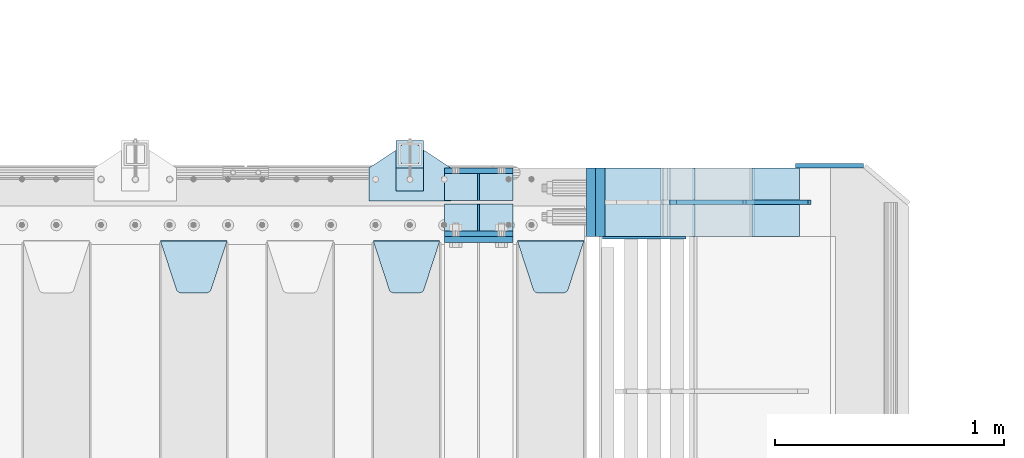
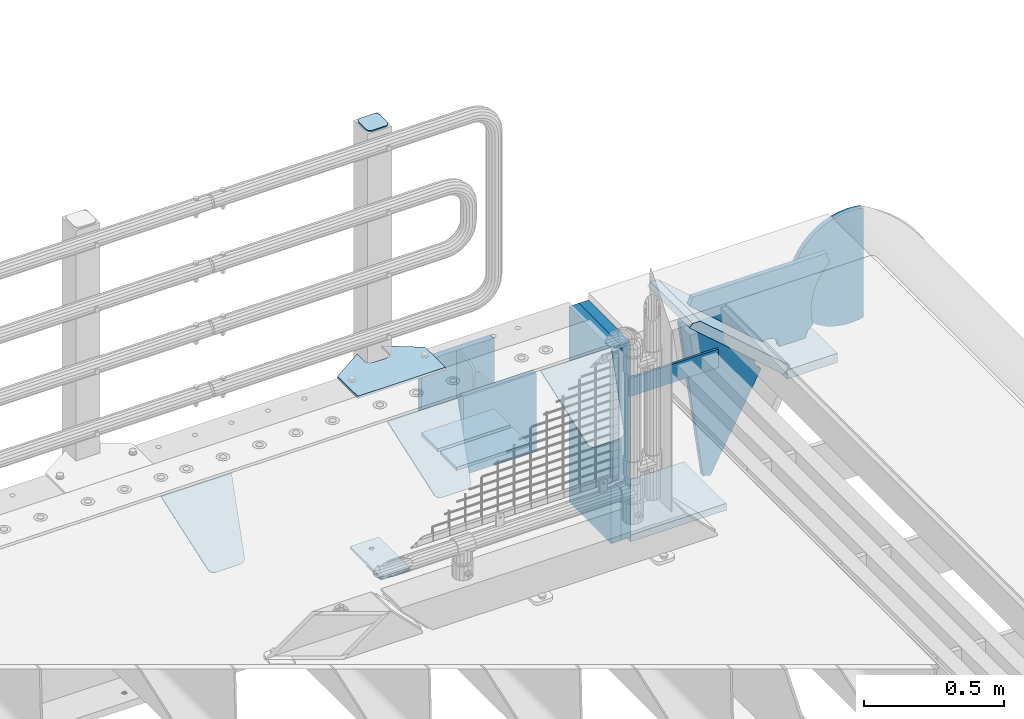
# One storey, part 193 of 208: 23 plates.
"""IFC2X3 building model written with IfcOpenShell, lengths in millimetres."""

from ifc_helpers import new_model, si_unit, frame, origin_with_axes, place, context, subcontext, project, spatial, faceted_brep, material, type_object, element, save


model = new_model("IFC2X3")

# Units and contexts
model_context = context("Model", 3, precision=1e-05, world=origin_with_axes())
body_context = subcontext(model_context, "Body", "Model", "MODEL_VIEW")
ifc_project = project(units=[si_unit("LENGTHUNIT", "METRE", prefix="MILLI"), si_unit("AREAUNIT", "SQUARE_METRE"), si_unit("VOLUMEUNIT", "CUBIC_METRE"), si_unit("MASSUNIT", "GRAM", prefix="KILO"), si_unit("TIMEUNIT", "SECOND"), si_unit("PLANEANGLEUNIT", "RADIAN"), si_unit("SOLIDANGLEUNIT", "STERADIAN"), si_unit("THERMODYNAMICTEMPERATUREUNIT", "DEGREE_CELSIUS"), si_unit("LUMINOUSINTENSITYUNIT", "LUMEN")], contexts=[model_context])

# Site, building, storey
site_placement = place(None, origin_with_axes())
site = spatial("IfcSite", under=ifc_project, at=site_placement, CompositionType="ELEMENT")
building_placement = place(site_placement, origin_with_axes())
building = spatial("IfcBuilding", under=site, at=building_placement, Name="Standard", CompositionType="ELEMENT")
storey_placement = place(building_placement, origin_with_axes())
storey = spatial("IfcBuildingStorey", under=building, at=storey_placement, Name="Undefined", CompositionType="ELEMENT", Elevation=0.0)

# Plates
ifc_material_1 = material(Name="STEEL/S355N")
plate_type_1 = type_object("IfcPlateType", PredefinedType="NOTDEFINED")
for number, where, z_axis, x_axis in (
    (1, (-26255.0, 6137.49999999999, -339.999999999993), (0.0, 0.0, 1.0), (1.0, 0.0, 0.0)),
    (2, (-26255.0, 5862.49999999999, -339.999999999993), (0.0, 0.0, 1.0), (1.0, 0.0, 0.0)),
):
    element("IfcPlate", number, at=place(storey_placement, frame(where, z_axis=z_axis, x_axis=x_axis)), inside=storey, type_object=plate_type_1, material=ifc_material_1, context=body_context, shape_type="Brep", body=[
        faceted_brep([(0.0, -12.5, 0.0), (0.0, -12.5, 310.0), (0.0, 12.5, 310.0), (0.0, 12.5, 0.0), (300.0, -12.5, 310.0), (300.0, 12.5, 310.0), (300.0, -12.5, 0.0), (300.0, 12.5, 0.0)], [[[0, 1, 2, 3]], [[1, 4, 5, 2]], [[4, 6, 7, 5]], [[6, 0, 3, 7]], [[5, 7, 3, 2]], [[6, 4, 1, 0]]]),
    ])
plate_1_placement = place(storey_placement, frame((-26255.0, 5837.5, -340.000000000044), z_axis=(0.0, 0.0, 1.0), x_axis=(1.0, 0.0, 0.0)))
element("IfcPlate", 3, at=plate_1_placement, inside=storey, type_object=plate_type_1, material=ifc_material_1, context=body_context, shape_type="Brep", body=[
    faceted_brep([(0.0, -12.5, 0.0), (0.0, -12.5, 340.0), (0.0, 12.5, 340.0), (0.0, 12.5, 0.0), (300.0, -12.5, 340.0), (300.0, 12.5, 340.0), (300.0, -12.5, 0.0), (300.0, 12.5, 0.0)], [[[0, 1, 2, 3]], [[1, 4, 5, 2]], [[4, 6, 7, 5]], [[6, 0, 3, 7]], [[5, 7, 3, 2]], [[6, 4, 1, 0]]]),
])
plate_type_2 = type_object("IfcPlateType", PredefinedType="NOTDEFINED")
for number, where, z_axis, x_axis in (
    (4, (-26255.0, 5991.99999999999, -342.999999999993), (0.0, -1.0, 0.0), (1.0, 0.0, 0.0)),
    (5, (-26255.0, 6007.99999999999, -342.999999999993), (0.0, 1.0, 0.0), (1.0, 0.0, 0.0)),
):
    element("IfcPlate", number, at=place(storey_placement, frame(where, z_axis=z_axis, x_axis=x_axis)), inside=storey, type_object=plate_type_2, material=ifc_material_1, context=body_context, shape_type="Brep", body=[
        faceted_brep([(0.0, -7.0, 0.0), (0.0, -7.0, 117.0), (0.0, 7.0, 117.0), (0.0, 7.0, 0.0), (300.0, -7.0, 117.0), (300.0, 7.0, 117.0), (300.0, -7.0, 0.0), (300.0, 7.0, 0.0)], [[[0, 1, 2, 3]], [[1, 4, 5, 2]], [[4, 6, 7, 5]], [[6, 0, 3, 7]], [[5, 7, 3, 2]], [[6, 4, 1, 0]]]),
    ])
plate_type_3 = type_object("IfcPlateType", PredefinedType="NOTDEFINED")
for number, where, z_axis, x_axis in (
    (6, (-26105.0, 6007.99999999999, -29.999999999993), (0.0, 0.0, -1.0), (0.0, 1.0, 0.0)),
    (7, (-26105.0, 5991.99999999999, -29.999999999993), (0.0, 0.0, -1.0), (0.0, -1.0, 0.0)),
):
    element("IfcPlate", number, at=place(storey_placement, frame(where, z_axis=z_axis, x_axis=x_axis)), inside=storey, type_object=plate_type_3, material=ifc_material_1, context=body_context, shape_type="Brep", body=[
        faceted_brep([(0.0, -5.0, 30.0), (0.0, -5.0, 306.0), (0.0, 5.0, 306.0), (0.0, 5.0, 30.0), (117.0, -5.0, 306.0), (117.0, 5.0, 306.0), (117.0, -5.0, 0.0), (117.0, 5.0, 0.0), (30.0, -5.0, 0.0), (30.0, 5.0, 0.0), (24.7905546699922, -5.0, 0.455767409633758), (24.7905546699922, 5.0, 0.455767409633758), (19.7393957002296, -5.0, 1.80922137642275), (19.7393957002296, 5.0, 1.80922137642275), (15.0, -5.0, 4.01923788646684), (15.0, 5.0, 4.01923788646684), (10.7163717094036, -5.0, 7.01866670643066), (10.7163717094036, 5.0, 7.01866670643066), (7.01866670643085, -5.0, 10.7163717094038), (7.01866670643085, 5.0, 10.7163717094038), (4.01923788646673, -5.0, 15.0), (4.01923788646673, 5.0, 15.0), (1.80922137642301, -5.0, 19.7393957002299), (1.80922137642301, 5.0, 19.7393957002299), (0.455767409634063, -5.0, 24.7905546699921), (0.455767409634063, 5.0, 24.7905546699921)], [[[0, 1, 2, 3]], [[1, 4, 5, 2]], [[4, 6, 7, 5]], [[6, 8, 9, 7]], [[8, 10, 11, 9]], [[10, 12, 13, 11]], [[12, 14, 15, 13]], [[14, 16, 17, 15]], [[16, 18, 19, 17]], [[18, 20, 21, 19]], [[20, 22, 23, 21]], [[22, 24, 25, 23]], [[24, 0, 3, 25]], [[5, 7, 9, 11, 13, 15, 17, 19, 21, 23, 25, 3, 2]], [[24, 22, 20, 18, 16, 14, 12, 10, 8, 6, 4, 1, 0]]]),
    ])
plate_type_4 = type_object("IfcPlateType", PredefinedType="NOTDEFINED")
plate_2_placement = place(storey_placement, frame((-25935.0, 5831.76776695596, -1.76776695296758), z_axis=(0.0, -0.707106781186548, -0.707106781186547), x_axis=(1.0, 0.0, 0.0)))
element("IfcPlate", 8, at=plate_2_placement, inside=storey, type_object=plate_type_4, material=ifc_material_1, context=body_context, shape_type="Brep", body=[
    faceted_brep([(0.0, -2.5, 0.0), (69.345504679477, -2.5, 300.17173142483), (69.345504679477, 2.5, 300.17173142483), (0.0, 2.5, 0.0), (70.9274061199576, -2.5, 304.897442415399), (70.9274061199576, 2.5, 304.8974424154), (73.3818627772307, -2.5, 309.234538108527), (73.3818627772307, 2.5, 309.234538108527), (76.6187032999551, -2.5, 313.023683126103), (76.6187032999551, 2.5, 313.023683126103), (80.5190132704993, -2.5, 316.125672595371), (80.5190132704993, 2.5, 316.125672595371), (84.9395038596849, -2.5, 318.426546230476), (84.9395038596849, 2.50000000000091, 318.426546230476), (89.7177759439219, -2.5, 319.841774983275), (89.7177759439219, 2.50000000000091, 319.841774983275), (94.678286292652, -2.49999999999909, 320.319366455078), (94.678286292652, 2.5, 320.319366455078), (195.321713707348, -2.49999999999909, 320.319366455078), (195.321713707348, 2.5, 320.319366455078), (200.282224056078, -2.5, 319.841774983275), (200.282224056078, 2.5, 319.841774983274), (205.060496140315, -2.5, 318.426546230475), (205.060496140315, 2.5, 318.426546230475), (209.480986729501, -2.5, 316.125672595371), (209.480986729501, 2.50000000000091, 316.125672595371), (213.381296700045, -2.5, 313.023683126102), (213.381296700045, 2.5, 313.023683126102), (216.618137222769, -2.5, 309.234538108526), (216.618137222769, 2.5, 309.234538108527), (219.072593880042, -2.5, 304.897442415399), (219.072593880042, 2.5, 304.897442415399), (220.654495320523, -2.5, 300.17173142483), (220.654495320523, 2.5, 300.17173142483), (290.0, -2.5, 0.0), (290.0, 2.5, 0.0)], [[[0, 1, 2, 3]], [[1, 4, 5, 2]], [[4, 6, 7, 5]], [[6, 8, 9, 7]], [[8, 10, 11, 9]], [[10, 12, 13, 11]], [[12, 14, 15, 13]], [[14, 16, 17, 15]], [[16, 18, 19, 17]], [[18, 20, 21, 19]], [[20, 22, 23, 21]], [[22, 24, 25, 23]], [[24, 26, 27, 25]], [[26, 28, 29, 27]], [[28, 30, 31, 29]], [[30, 32, 33, 31]], [[32, 34, 35, 33]], [[34, 0, 3, 35]], [[5, 7, 9, 11, 13, 15, 17, 19, 21, 23, 25, 27, 29, 31, 33, 35, 3, 2]], [[34, 32, 30, 28, 26, 24, 22, 20, 18, 16, 14, 12, 10, 8, 6, 4, 1, 0]]]),
])
plate_3_placement = place(storey_placement, frame((-26565.0, 5831.76776695596, -1.76776695296758), z_axis=(0.0, -0.707106781186548, -0.707106781186547), x_axis=(1.0, 0.0, 0.0)))
element("IfcPlate", 9, at=plate_3_placement, inside=storey, type_object=plate_type_4, material=ifc_material_1, context=body_context, shape_type="Brep", body=[
    faceted_brep([(0.0, -2.5, 0.0), (69.345504679477, -2.5, 300.17173142483), (69.345504679477, 2.5, 300.17173142483), (0.0, 2.5, 0.0), (70.9274061199576, -2.5, 304.897442415399), (70.9274061199576, 2.5, 304.8974424154), (73.3818627772307, -2.5, 309.234538108527), (73.3818627772307, 2.5, 309.234538108527), (76.6187032999551, -2.5, 313.023683126103), (76.6187032999551, 2.5, 313.023683126103), (80.5190132704993, -2.5, 316.125672595371), (80.5190132704993, 2.5, 316.125672595371), (84.9395038596849, -2.5, 318.426546230476), (84.9395038596849, 2.50000000000091, 318.426546230476), (89.7177759439219, -2.5, 319.841774983275), (89.7177759439219, 2.50000000000091, 319.841774983275), (94.678286292652, -2.49999999999909, 320.319366455078), (94.678286292652, 2.5, 320.319366455078), (195.321713707348, -2.49999999999909, 320.319366455078), (195.321713707348, 2.5, 320.319366455078), (200.282224056078, -2.5, 319.841774983275), (200.282224056078, 2.5, 319.841774983274), (205.060496140315, -2.5, 318.426546230475), (205.060496140315, 2.5, 318.426546230475), (209.480986729501, -2.5, 316.125672595371), (209.480986729501, 2.50000000000091, 316.125672595371), (213.381296700045, -2.5, 313.023683126102), (213.381296700045, 2.5, 313.023683126102), (216.618137222769, -2.5, 309.234538108526), (216.618137222769, 2.5, 309.234538108527), (219.072593880042, -2.5, 304.897442415399), (219.072593880042, 2.5, 304.897442415399), (220.654495320523, -2.5, 300.17173142483), (220.654495320523, 2.5, 300.17173142483), (290.0, -2.5, 0.0), (290.0, 2.5, 0.0)], [[[0, 1, 2, 3]], [[1, 4, 5, 2]], [[4, 6, 7, 5]], [[6, 8, 9, 7]], [[8, 10, 11, 9]], [[10, 12, 13, 11]], [[12, 14, 15, 13]], [[14, 16, 17, 15]], [[16, 18, 19, 17]], [[18, 20, 21, 19]], [[20, 22, 23, 21]], [[22, 24, 25, 23]], [[24, 26, 27, 25]], [[26, 28, 29, 27]], [[28, 30, 31, 29]], [[30, 32, 33, 31]], [[32, 34, 35, 33]], [[34, 0, 3, 35]], [[5, 7, 9, 11, 13, 15, 17, 19, 21, 23, 25, 27, 29, 31, 33, 35, 3, 2]], [[34, 32, 30, 28, 26, 24, 22, 20, 18, 16, 14, 12, 10, 8, 6, 4, 1, 0]]]),
])
plate_4_placement = place(storey_placement, frame((-27495.0, 5831.76776695596, -1.76776695296758), z_axis=(0.0, -0.707106781186548, -0.707106781186547), x_axis=(1.0, 0.0, 0.0)))
element("IfcPlate", 10, at=plate_4_placement, inside=storey, type_object=plate_type_4, material=ifc_material_1, context=body_context, shape_type="Brep", body=[
    faceted_brep([(0.0, -2.5, 0.0), (69.345504679477, -2.5, 300.17173142483), (69.345504679477, 2.5, 300.17173142483), (0.0, 2.5, 0.0), (70.9274061199576, -2.5, 304.897442415399), (70.9274061199576, 2.5, 304.8974424154), (73.3818627772307, -2.5, 309.234538108527), (73.3818627772307, 2.5, 309.234538108527), (76.6187032999551, -2.5, 313.023683126103), (76.6187032999551, 2.5, 313.023683126103), (80.5190132704993, -2.5, 316.125672595371), (80.5190132704993, 2.5, 316.125672595371), (84.9395038596849, -2.5, 318.426546230476), (84.9395038596849, 2.50000000000091, 318.426546230476), (89.7177759439219, -2.5, 319.841774983275), (89.7177759439219, 2.50000000000091, 319.841774983275), (94.678286292652, -2.49999999999909, 320.319366455078), (94.678286292652, 2.5, 320.319366455078), (195.321713707348, -2.49999999999909, 320.319366455078), (195.321713707348, 2.5, 320.319366455078), (200.282224056078, -2.5, 319.841774983275), (200.282224056078, 2.5, 319.841774983274), (205.060496140315, -2.5, 318.426546230475), (205.060496140315, 2.5, 318.426546230475), (209.480986729501, -2.5, 316.125672595371), (209.480986729501, 2.50000000000091, 316.125672595371), (213.381296700045, -2.5, 313.023683126102), (213.381296700045, 2.5, 313.023683126102), (216.618137222769, -2.5, 309.234538108526), (216.618137222769, 2.5, 309.234538108527), (219.072593880042, -2.5, 304.897442415399), (219.072593880042, 2.5, 304.897442415399), (220.654495320523, -2.5, 300.17173142483), (220.654495320523, 2.5, 300.17173142483), (290.0, -2.5, 0.0), (290.0, 2.5, 0.0)], [[[0, 1, 2, 3]], [[1, 4, 5, 2]], [[4, 6, 7, 5]], [[6, 8, 9, 7]], [[8, 10, 11, 9]], [[10, 12, 13, 11]], [[12, 14, 15, 13]], [[14, 16, 17, 15]], [[16, 18, 19, 17]], [[18, 20, 21, 19]], [[20, 22, 23, 21]], [[22, 24, 25, 23]], [[24, 26, 27, 25]], [[26, 28, 29, 27]], [[28, 30, 31, 29]], [[30, 32, 33, 31]], [[32, 34, 35, 33]], [[34, 0, 3, 35]], [[5, 7, 9, 11, 13, 15, 17, 19, 21, 23, 25, 27, 29, 31, 33, 35, 3, 2]], [[34, 32, 30, 28, 26, 24, 22, 20, 18, 16, 14, 12, 10, 8, 6, 4, 1, 0]]]),
])
ifc_material_2 = material(Name="STEEL/S355J2")
plate_type_5 = type_object("IfcPlateType", PredefinedType="NOTDEFINED")
plate_5_placement = place(storey_placement, frame((-26585.0, 6005.0, 5.00000000004911), z_axis=(0.0, 1.0, 0.0), x_axis=(1.0, 0.0, 0.0)))
element("IfcPlate", 11, at=plate_5_placement, inside=storey, type_object=plate_type_5, material=ifc_material_2, context=body_context, shape_type="Brep", body=[
    faceted_brep([(0.0, -5.0, 0.0), (2.31396552408114e-06, -5.0, 145.0), (2.31396552408114e-06, 5.0, 145.0), (0.0, 5.0, 0.0), (130.0, -5.0, 230.0), (130.0, 5.0, 230.0), (130.0, -5.0, 180.0), (130.0, 5.0, 180.0), (130.48036798992, -5.0, 175.122741949597), (130.48036798992, 5.0, 175.122741949597), (131.903011687216, -5.0, 170.432914190873), (131.903011687216, 5.0, 170.432914190873), (134.213259692435, -5.0, 166.11074417451), (134.213259692435, 5.0, 166.11074417451), (137.322330470335, -5.0, 162.322330470336), (137.322330470335, 5.0, 162.322330470336), (141.110744174512, -5.0, 159.213259692437), (141.110744174512, 5.0, 159.213259692437), (145.432914190871, -5.0, 156.903011687218), (145.432914190871, 5.0, 156.903011687218), (150.122741949595, -5.0, 155.48036798992), (150.122741949595, 5.0, 155.48036798992), (155.0, -5.0, 155.0), (155.0, 5.0, 155.0), (205.0, -5.0, 155.0), (205.0, 5.0, 155.0), (209.877258050405, -5.0, 155.48036798992), (209.877258050405, 5.0, 155.48036798992), (214.567085809129, -5.0, 156.903011687218), (214.567085809129, 5.0, 156.903011687218), (218.889255825488, -5.0, 159.213259692437), (218.889255825488, 5.0, 159.213259692437), (222.677669529665, -5.0, 162.322330470336), (222.677669529665, 5.0, 162.322330470336), (225.786740307565, -5.0, 166.11074417451), (225.786740307565, 5.0, 166.11074417451), (228.096988312784, -5.0, 170.432914190873), (228.096988312784, 5.0, 170.432914190873), (229.51963201008, -5.0, 175.122741949597), (229.51963201008, 5.0, 175.122741949597), (230.0, -5.0, 180.0), (230.0, 5.0, 180.0), (230.0, -5.0, 230.0), (230.0, 5.0, 230.0), (360.0, -5.0, 145.0), (360.0, 5.0, 145.0), (360.0, -5.0, -7.27595761418343e-12), (360.0, 5.0, -7.27595761418343e-12)], [[[0, 1, 2, 3]], [[1, 4, 5, 2]], [[4, 6, 7, 5]], [[6, 8, 9, 7]], [[8, 10, 11, 9]], [[10, 12, 13, 11]], [[12, 14, 15, 13]], [[14, 16, 17, 15]], [[16, 18, 19, 17]], [[18, 20, 21, 19]], [[20, 22, 23, 21]], [[22, 24, 25, 23]], [[24, 26, 27, 25]], [[26, 28, 29, 27]], [[28, 30, 31, 29]], [[30, 32, 33, 31]], [[32, 34, 35, 33]], [[34, 36, 37, 35]], [[36, 38, 39, 37]], [[38, 40, 41, 39]], [[40, 42, 43, 41]], [[42, 44, 45, 43]], [[44, 46, 47, 45]], [[46, 0, 3, 47]], [[5, 7, 9, 11, 13, 15, 17, 19, 21, 23, 25, 27, 29, 31, 33, 35, 37, 39, 41, 43, 45, 47, 3, 2]], [[46, 44, 42, 40, 38, 36, 34, 32, 30, 28, 26, 24, 22, 20, 18, 16, 14, 12, 10, 8, 6, 4, 1, 0]]]),
])
plate_type_6 = type_object("IfcPlateType", PredefinedType="NOTDEFINED")
plate_6_placement = place(storey_placement, frame((-26464.9999999999, 6050.00000000021, -850.000000000002), z_axis=(0.0, 1.0, 0.0), x_axis=(1.0, 0.0, 0.0)))
element("IfcPlate", 12, at=plate_6_placement, inside=storey, type_object=plate_type_6, material=ifc_material_2, context=body_context, shape_type="Brep", body=[
    faceted_brep([(66.3639610305399, -5.0, 163.636038969112), (66.3639610305399, 5.0, 163.636038969112), (59.9999999998618, 5.0, 160.999999999791), (59.9999999998618, -5.0, 160.999999999791), (53.6360389691836, 5.0, 163.636038969112), (53.6360389691836, -5.0, 163.636038969112), (50.9999999998618, 5.0, 169.999999999791), (50.9999999998618, -5.0, 169.999999999791), (53.6360389691836, 5.0, 176.36396103047), (53.6360389691836, -5.0, 176.36396103047), (59.9999999998618, 5.0, 178.999999999791), (59.9999999998618, -5.0, 178.999999999791), (66.3639610305399, 5.0, 176.36396103047), (66.3639610305399, -5.0, 176.36396103047), (68.9999999998618, 5.0, 169.999999999791), (68.9999999998618, -5.0, 169.999999999791), (120.0, -5.0, 0.0), (120.0, -5.0, 220.0), (0.0, -5.0, 220.0), (0.0, -5.0, 0.0), (0.0, 5.0, 0.0), (120.0, 5.0, 0.0), (120.0, 5.0, 220.0), (0.0, 5.0, 220.0)], [[[0, 1, 2, 3]], [[3, 2, 4, 5]], [[5, 4, 6, 7]], [[7, 6, 8, 9]], [[9, 8, 10, 11]], [[11, 10, 12, 13]], [[13, 12, 14, 15]], [[15, 14, 1, 0]], [[16, 17, 18, 19], [3, 5, 7, 9, 11, 13, 15, 0]], [[16, 19, 20, 21]], [[17, 16, 21, 22]], [[18, 17, 22, 23]], [[19, 18, 23, 20]], [[22, 21, 20, 23], [10, 8, 6, 4, 2, 1, 14, 12]]]),
])
plate_type_7 = type_object("IfcPlateType", PredefinedType="NOTDEFINED")
plate_7_placement = place(storey_placement, frame((-26360.9999999999, 6166.00000000021, 1012.50000000001), z_axis=(0.0, 1.0, 0.0), x_axis=(-1.0, 0.0, 0.0)))
element("IfcPlate", 13, at=plate_7_placement, inside=storey, type_object=plate_type_7, material=ifc_material_2, context=body_context, shape_type="Brep", body=[
    faceted_brep([(0.0, -2.5, 19.0), (0.0, -2.5, 69.0), (0.0, 2.5, 69.0), (0.0, 2.5, 19.0), (0.476369668544066, -2.5, 73.2278977451697), (0.476369668544066, 2.5, 73.2278977451697), (1.88159150985302, -2.5, 77.2437910432336), (1.88159150985302, 2.5, 77.2437910432336), (4.14520183310742, -2.5, 80.8463062353158), (4.14520183310742, 2.5, 80.8463062353158), (7.15369376468516, -2.5, 83.8547981668926), (7.15369376468516, 2.5, 83.8547981668926), (10.7562089567655, -2.5, 86.1184084901461), (10.7562089567655, 2.5, 86.1184084901461), (14.7721022548285, -2.5, 87.523630331455), (14.7721022548285, 2.5, 87.523630331455), (19.0, -2.5, 88.0), (19.0, 2.5, 88.0), (69.0, -2.5, 88.0), (69.0, 2.5, 88.0), (73.2278977451715, -2.5, 87.523630331455), (73.2278977451715, 2.5, 87.523630331455), (77.2437910432345, -2.5, 86.1184084901461), (77.2437910432345, 2.5, 86.1184084901461), (80.8463062353148, -2.5, 83.8547981668926), (80.8463062353148, 2.5, 83.8547981668926), (83.8547981668926, -2.5, 80.8463062353158), (83.8547981668926, 2.5, 80.8463062353158), (86.118408490147, -2.5, 77.2437910432336), (86.118408490147, 2.5, 77.2437910432336), (87.5236303314559, -2.5, 73.2278977451697), (87.5236303314559, 2.5, 73.2278977451697), (88.0, -2.5, 69.0), (88.0, 2.5, 69.0), (88.0, -2.5, 19.0), (88.0, 2.5, 19.0), (87.5236303314559, -2.5, 14.7721022548303), (87.5236303314559, 2.5, 14.7721022548303), (86.118408490147, -2.5, 10.7562089567664), (86.118408490147, 2.5, 10.7562089567664), (83.8547981668926, -2.5, 7.15369376468425), (83.8547981668926, 2.5, 7.15369376468425), (80.8463062353148, -2.5, 4.14520183310742), (80.8463062353148, 2.5, 4.14520183310742), (77.2437910432345, -2.5, 1.88159150985393), (77.2437910432345, 2.5, 1.88159150985393), (73.2278977451715, -2.5, 0.476369668544976), (73.2278977451715, 2.5, 0.476369668544976), (69.0, -2.5, 0.0), (69.0, 2.5, 0.0), (19.0, -2.5, 0.0), (19.0, 2.5, 0.0), (14.7721022548285, -2.5, 0.476369668544976), (14.7721022548285, 2.5, 0.476369668544976), (10.7562089567655, -2.5, 1.88159150985393), (10.7562089567655, 2.5, 1.88159150985393), (7.15369376468516, -2.5, 4.14520183310742), (7.15369376468516, 2.5, 4.14520183310742), (4.14520183310742, -2.5, 7.15369376468425), (4.14520183310742, 2.5, 7.15369376468425), (1.88159150985302, -2.5, 10.7562089567664), (1.88159150985302, 2.5, 10.7562089567664), (0.476369668544066, -2.5, 14.7721022548303), (0.476369668544066, 2.5, 14.7721022548303)], [[[0, 1, 2, 3]], [[1, 4, 5, 2]], [[4, 6, 7, 5]], [[6, 8, 9, 7]], [[8, 10, 11, 9]], [[10, 12, 13, 11]], [[12, 14, 15, 13]], [[14, 16, 17, 15]], [[16, 18, 19, 17]], [[18, 20, 21, 19]], [[20, 22, 23, 21]], [[22, 24, 25, 23]], [[24, 26, 27, 25]], [[26, 28, 29, 27]], [[28, 30, 31, 29]], [[30, 32, 33, 31]], [[32, 34, 35, 33]], [[34, 36, 37, 35]], [[36, 38, 39, 37]], [[38, 40, 41, 39]], [[40, 42, 43, 41]], [[42, 44, 45, 43]], [[44, 46, 47, 45]], [[46, 48, 49, 47]], [[48, 50, 51, 49]], [[50, 52, 53, 51]], [[52, 54, 55, 53]], [[54, 56, 57, 55]], [[56, 58, 59, 57]], [[58, 60, 61, 59]], [[60, 62, 63, 61]], [[62, 0, 3, 63]], [[5, 7, 9, 11, 13, 15, 17, 19, 21, 23, 25, 27, 29, 31, 33, 35, 37, 39, 41, 43, 45, 47, 49, 51, 53, 55, 57, 59, 61, 63, 3, 2]], [[62, 60, 58, 56, 54, 52, 50, 48, 46, 44, 42, 40, 38, 36, 34, 32, 30, 28, 26, 24, 22, 20, 18, 16, 14, 12, 10, 8, 6, 4, 1, 0]]]),
])
plate_type_8 = type_object("IfcPlateType", PredefinedType="NOTDEFINED")
plate_8_placement = place(storey_placement, frame((-26464.9999999999, 6050.00000000021, -857.500000000002), z_axis=(0.0, 1.0, 0.0), x_axis=(1.0, 0.0, 0.0)))
element("IfcPlate", 14, at=plate_8_placement, inside=storey, type_object=plate_type_8, material=ifc_material_2, context=body_context, shape_type="Brep", body=[
    faceted_brep([(0.0, -2.5, 0.0), (0.0, -2.5, 100.0), (0.0, 2.5, 100.0), (0.0, 2.5, 0.0), (120.0, -2.5, 100.0), (120.0, 2.5, 100.0), (120.0, -2.5, 0.0), (120.0, 2.5, 0.0)], [[[0, 1, 2, 3]], [[1, 4, 5, 2]], [[4, 6, 7, 5]], [[6, 0, 3, 7]], [[5, 7, 3, 2]], [[6, 4, 1, 0]]]),
])
plate_type_9 = type_object("IfcPlateType", PredefinedType="NOTDEFINED")
plate_9_placement = place(storey_placement, frame((-24911.0011701102, 5849.9999999992, -387.999999999302), z_axis=(1.0, 0.0, 0.0), x_axis=(0.0, 1.0, 0.0)))
element("IfcPlate", 15, at=plate_9_placement, inside=storey, type_object=plate_type_9, material=ifc_material_1, context=body_context, shape_type="Brep", body=[
    faceted_brep([(0.0, -20.0, 0.0), (3.31056071445346e-10, -20.0, 208.0), (3.31056071445346e-10, 20.0, 208.0), (0.0, 20.0, 0.0), (300.0, -20.0, 208.0), (300.0, 20.0, 208.0), (300.0, -20.0, 3.63797880709171e-12), (300.0, 20.0, 3.63797880709171e-12)], [[[0, 1, 2, 3]], [[1, 4, 5, 2]], [[4, 6, 7, 5]], [[6, 0, 3, 7]], [[5, 7, 3, 2]], [[6, 4, 1, 0]]]),
])
plate_type_10 = type_object("IfcPlateType", PredefinedType="NOTDEFINED")
plate_10_placement = place(storey_placement, frame((-25160.0011701109, 6150.0, -875.000000003253), z_axis=(0.0, -1.0, 0.0), x_axis=(-1.0, 0.0, 0.0)))
element("IfcPlate", 16, at=plate_10_placement, inside=storey, type_object=plate_type_10, material=ifc_material_1, context=body_context, shape_type="Brep", body=[
    faceted_brep([(0.0, -15.0, 0.0), (0.0, -15.0, 300.0), (0.0, 15.0, 300.0), (0.0, 15.0, 0.0), (393.0, -15.0, 300.0), (393.0, 15.0, 300.0), (393.0, -15.0, 1.50635059981141e-12), (393.0, 15.0, 1.50635059981141e-12)], [[[0, 1, 2, 3]], [[1, 4, 5, 2]], [[4, 6, 7, 5]], [[6, 0, 3, 7]], [[5, 7, 3, 2]], [[6, 4, 1, 0]]]),
])
plate_type_11 = type_object("IfcPlateType", PredefinedType="NOTDEFINED")
plate_11_placement = place(storey_placement, frame((-24911.0011701102, 6149.9999999992, -367.999999999302), z_axis=(-0.752989422949573, 0.0, 0.658032619955933), x_axis=(0.0, -1.0, 0.0)))
element("IfcPlate", 17, at=plate_11_placement, inside=storey, type_object=plate_type_11, material=ifc_material_1, context=body_context, shape_type="Brep", body=[
    faceted_brep([(-8.10757683211705e-10, 20.0, 490.766265601625), (4.54747350886464e-13, -0.30381125094209, 514.000000000004), (300.0, -0.30381125094209, 514.000000000004), (300.0, 20.0, 490.766265601625), (300.0, -20.0, 3.63797880709171e-12), (300.0, -20.0, 514.000000000004), (4.54747350886464e-13, -20.0, 514.000000000004), (0.0, -20.0, 0.0), (0.0, 20.0, 0.0), (300.0, 20.0, 3.63797880709171e-12)], [[[0, 1, 2, 3]], [[4, 5, 6, 7]], [[4, 7, 8, 9]], [[9, 8, 0, 3]], [[5, 4, 9, 3, 2]], [[6, 5, 2, 1]], [[8, 7, 6, 1, 0]]]),
])
ifc_material_3 = material()
for number, where, z_axis, x_axis in (
    (18, (-25573.0011701094, 6150.0, -870.000000000003), (0.0, 0.0, 1.0), (0.0, -1.0, 0.0)),
    (19, (-25613.0, 6150.0, -870.0), (0.0, 0.0, 1.0), (0.0, -1.0, 0.0)),
):
    element("IfcPlate", number, at=place(storey_placement, frame(where, z_axis=z_axis, x_axis=x_axis)), inside=storey, type_object=plate_type_11, material=ifc_material_3, context=body_context, shape_type="Brep", body=[
        faceted_brep([(0.0, -20.0, 0.0), (9.5367431640625e-07, -20.0, 850.0), (9.5367431640625e-07, 20.0, 850.0), (0.0, 20.0, 0.0), (300.0, -20.0, 850.0), (300.0, 20.0, 850.0), (300.0, -20.0, 3.63797880709171e-12), (300.0, 20.0, 3.63797880709171e-12)], [[[0, 1, 2, 3]], [[1, 4, 5, 2]], [[4, 6, 7, 5]], [[6, 0, 3, 7]], [[5, 7, 3, 2]], [[6, 4, 1, 0]]]),
    ])
plate_type_12 = type_object("IfcPlateType", PredefinedType="NOTDEFINED")
plate_12_placement = place(storey_placement, frame((-24596.0011701102, 5999.99999999936, -29.9999999993023), z_axis=(-0.000446694000102124, 0.0, -0.99999990023223), x_axis=(-0.99999990023223, 0.0, 0.000446694000103734)))
element("IfcPlate", 20, at=plate_12_placement, inside=storey, type_object=plate_type_12, material=ifc_material_1, context=body_context, shape_type="Brep", body=[
    faceted_brep([(125.007775472979, 10.0, 291.842314882029), (131.755016800049, 10.0, 263.793234614468), (131.755016800049, -10.0, 263.793234614468), (125.007775472979, -10.0, 291.842314882029), (134.899927074479, 10.0, 224.060281342732), (134.899927074479, -10.0, 224.060281342732), (131.790514995217, 10.0, 184.324534302446), (131.790514995217, -10.0, 184.324534302446), (122.503344607205, 10.0, 145.564419461128), (122.503344607205, -10.0, 145.564419461128), (107.267096867741, 10.0, 108.734339483615), (107.267096867741, -10.0, 108.734339483615), (86.4569387623887, 10.0, 74.7411731709829), (86.4569387623887, -10.0, 74.7411731709829), (60.5852854486475, 10.0, 44.4219450946983), (60.5852854486475, -10.0, 44.4219450946983), (56.2519855253086, 10.0, 40.7176084148888), (56.2519855253086, -10.0, 40.7176084148888), (136.409234539125, -10.0, 297.721677540594), (147.386991180581, -10.0, 308.778803581017), (147.386991180581, 10.0, 308.778803581017), (136.409234539125, 10.0, 297.721677540594), (154.428166132755, -10.0, 322.678193223937), (154.428166132755, 10.0, 322.678193223937), (156.849001662973, -10.0, 338.070097995228), (156.849001662973, 10.0, 338.070097995228), (264.849004013293, -10.0, 338.118348049693), (264.849004013293, 10.0, 338.118348049693), (267.62876711955, -10.0, 321.701412969031), (267.62876711955, 10.0, 321.701412969031), (275.645118712175, -10.0, 307.107546191754), (275.645118712175, 10.0, 307.107546191754), (288.009068357209, -10.0, 295.955165748785), (288.009068357209, 10.0, 295.955165748785), (303.34948944753, -10.0, 289.481038692482), (303.34948944753, 10.0, 289.481038692482), (319.965173216922, -10.0, 288.403127172445), (319.965173216922, 10.0, 288.403127172445), (336.013487920231, -10.0, 292.840968489265), (336.013487920231, 10.0, 292.840968489265), (335.86907958984, -10.0, 293.150054931641), (335.86907958984, 10.0, 293.150054931641), (633.93705743644, -10.0, 32.8861672876965), (633.93705743644, 10.0, 32.8861672876965), (628.672097726398, -10.0, 25.6357574923157), (628.672097726398, 10.0, 25.6357574923157), (624.785781531267, -10.0, 17.5620477266101), (624.785781531267, 10.0, 17.5620477266101), (622.402919050601, -10.0, 8.92432757904926), (622.402919050601, 10.0, 8.92432757904926), (621.600036621094, -10.0, -8.74678107720683e-10), (621.600036621094, 10.0, -8.74678107720683e-10), (70.0, -10.0, -9.85025394584227e-11), (70.0, 10.0, -9.85025394584227e-11), (67.7728137216582, -10.0, 17.5170123094482), (67.7728137216582, 10.0, 17.5170123094482), (61.2329794213947, -10.0, 33.9193489203215), (61.2329794213947, 10.0, 33.9193489203215)], [[[0, 1, 2, 3]], [[4, 5, 2, 1]], [[6, 7, 5, 4]], [[8, 9, 7, 6]], [[10, 11, 9, 8]], [[12, 13, 11, 10]], [[14, 15, 13, 12]], [[16, 17, 15, 14]], [[18, 19, 20, 21]], [[19, 22, 23, 20]], [[22, 24, 25, 23]], [[24, 26, 27, 25]], [[26, 28, 29, 27]], [[28, 30, 31, 29]], [[30, 32, 33, 31]], [[32, 34, 35, 33]], [[34, 36, 37, 35]], [[36, 38, 39, 37]], [[38, 40, 41, 39]], [[40, 42, 43, 41]], [[42, 44, 45, 43]], [[44, 46, 47, 45]], [[46, 48, 49, 47]], [[48, 50, 51, 49]], [[50, 52, 53, 51]], [[52, 54, 55, 53]], [[54, 56, 57, 55]], [[12, 10, 8, 6, 4, 1, 0, 21, 20, 23, 25, 27, 29, 31, 33, 35, 37, 39, 41, 43, 45, 47, 49, 51, 53, 55, 57, 16, 14]], [[18, 21, 0, 3]], [[56, 54, 52, 50, 48, 46, 44, 42, 40, 38, 36, 34, 32, 30, 28, 26, 24, 22, 19, 18, 3, 2, 5, 7, 9, 11, 13, 15, 17]], [[57, 56, 17, 16]]]),
])
plate_type_13 = type_object("IfcPlateType", PredefinedType="NOTDEFINED")
plate_13_placement = place(storey_placement, frame((-24911.9974314966, 6000.000000001, -393.996688204407), z_axis=(-0.658066357015091, 0.0, -0.752959939017267), x_axis=(-0.752959939017268, 0.0, 0.65806635701509)))
element("IfcPlate", 21, at=plate_13_placement, inside=storey, type_object=plate_type_13, material=ifc_material_1, context=body_context, shape_type="Brep", body=[
    faceted_brep([(-11.3595226159632, -10.0, 48.6925173505915), (-112.015767301036, -10.0, 480.154833723627), (-112.015767301036, 10.0, 480.154833723627), (-11.3595226159632, 10.0, 48.6925173505915), (-104.567323293642, -10.0, 482.519601382544), (-104.567323293642, 10.0, 482.519601382544), (-97.5783311599989, -10.0, 486.016090073754), (-97.5783311599989, 10.0, 486.016090073754), (-91.2195220373833, -10.0, 490.558885551658), (-91.2195220373833, 10.0, 490.558885551658), (-85.646232588424, -10.0, 496.037013784004), (-85.646232588424, 10.0, 496.037013784004), (447.024482710491, -10.0, 32.8103372896367), (447.024482710491, 10.0, 32.8103372896367), (441.786973010392, -10.0, 25.5709623937255), (441.786973010392, 10.0, 25.5709623937255), (437.921644570128, -10.0, 17.5149526624118), (437.921644570128, 10.0, 17.5149526624118), (435.551940606492, -10.0, 8.89958500531793), (435.551940606492, 10.0, 8.89958500531793), (434.753540039059, -10.0, -5.16592990607023e-10), (434.753540039059, 10.0, -5.16592990607023e-10), (50.0, -10.0, 0.0), (50.0, 10.0, 0.0), (47.7668538974212, -10.0, 14.7759151575156), (47.7668538974212, 10.0, 14.7759151575156), (41.2668932502784, -10.0, 28.2319592212443), (41.2668932502784, 10.0, 28.2319592212443), (31.0807325300157, -10.0, 39.1661596968297), (31.0807325300157, 10.0, 39.1661596968297), (18.1182591411452, -10.0, 46.6018098971945), (18.1182591411452, 10.0, 46.6018098971945), (3.53735696080548, -10.0, 49.874714091733), (3.53735696080548, 10.0, 49.874714091733)], [[[0, 1, 2, 3]], [[1, 4, 5, 2]], [[4, 6, 7, 5]], [[6, 8, 9, 7]], [[8, 10, 11, 9]], [[10, 12, 13, 11]], [[12, 14, 15, 13]], [[14, 16, 17, 15]], [[16, 18, 19, 17]], [[18, 20, 21, 19]], [[20, 22, 23, 21]], [[22, 24, 25, 23]], [[24, 26, 27, 25]], [[26, 28, 29, 27]], [[28, 30, 31, 29]], [[30, 32, 33, 31]], [[32, 0, 3, 33]], [[5, 7, 9, 11, 13, 15, 17, 19, 21, 23, 25, 27, 29, 31, 33, 3, 2]], [[32, 30, 28, 26, 24, 22, 20, 18, 16, 14, 12, 10, 8, 6, 4, 1, 0]]]),
])
plate_type_14 = type_object("IfcPlateType", PredefinedType="NOTDEFINED")
plate_14_placement = place(storey_placement, frame((-24233.0011701094, 6160.0, -498.000000000001), z_axis=(0.0, 0.0, 1.0), x_axis=(-1.0, 0.0, 0.0)))
element("IfcPlate", 22, at=plate_14_placement, inside=storey, type_object=plate_type_14, material=ifc_material_1, context=body_context, shape_type="Brep", body=[
    faceted_brep([(244.0, -10.0, 0.0), (209.275179461318, -10.0, 2.48356818105242), (209.275179461318, 10.0, 2.48356818105242), (244.0, 10.0, 0.0), (278.724820538682, -10.0, 2.48356818105236), (278.724820538682, 10.0, 2.48356818105236), (312.742743869308, -10.0, 9.88371443806261), (312.742743869308, 10.0, 9.88371443806261), (345.361263172461, -10.0, 22.0497931334975), (345.361263172461, 10.0, 22.0497931334975), (375.916359459166, -10.0, 38.7341379891918), (375.916359459166, 10.0, 38.7341379891918), (403.78601908265, -10.0, 59.597103857561), (403.78601908265, 10.0, 59.597103857561), (428.402896142437, -10.0, 84.2139809173505), (428.402896142437, 10.0, 84.2139809173505), (449.265862010809, -10.0, 112.083640540834), (449.265862010809, 10.0, 112.083640540834), (465.950206866502, -10.0, 142.63873682754), (465.950206866502, 10.0, 142.63873682754), (478.116285561937, -10.0, 175.257256130691), (478.116285561937, 10.0, 175.257256130691), (485.516431818949, -10.0, 209.275179461318), (485.516431818949, 10.0, 209.275179461318), (488.0, -10.0, 244.0), (488.0, 10.0, 244.0), (485.516431818949, -10.0, 278.724820538682), (485.516431818949, 10.0, 278.724820538682), (478.116285561937, -10.0, 312.742743869309), (478.116285561937, 10.0, 312.742743869309), (465.950206866502, -10.0, 345.36126317246), (465.950206866502, 10.0, 345.36126317246), (449.265862010809, -10.0, 375.916359459166), (449.265862010809, 10.0, 375.916359459166), (428.402896142437, -10.0, 403.78601908265), (428.402896142437, 10.0, 403.78601908265), (403.78601908265, -10.0, 428.402896142439), (403.78601908265, 10.0, 428.402896142439), (375.916359459166, -10.0, 449.265862010808), (375.916359459166, 10.0, 449.265862010808), (345.361263172461, -10.0, 465.950206866503), (345.361263172461, 10.0, 465.950206866503), (312.742743869308, -10.0, 478.116285561937), (312.742743869308, 10.0, 478.116285561937), (278.724820538682, -10.0, 485.516431818948), (278.724820538682, 10.0, 485.516431818948), (244.0, -10.0, 488.0), (244.0, 10.0, 488.0), (209.275179461318, -10.0, 485.516431818948), (209.275179461318, 10.0, 485.516431818948), (190.055415081217, -10.0, 481.335427997648), (190.058547913366, -10.0, 6.66389049643283), (190.053997906714, 10.0, 6.66488028979461), (190.050865087629, 10.0, 481.334438207128)], [[[0, 1, 2, 3]], [[4, 0, 3, 5]], [[6, 4, 5, 7]], [[8, 6, 7, 9]], [[10, 8, 9, 11]], [[12, 10, 11, 13]], [[14, 12, 13, 15]], [[16, 14, 15, 17]], [[18, 16, 17, 19]], [[20, 18, 19, 21]], [[22, 20, 21, 23]], [[24, 22, 23, 25]], [[26, 24, 25, 27]], [[28, 26, 27, 29]], [[30, 28, 29, 31]], [[32, 30, 31, 33]], [[34, 32, 33, 35]], [[36, 34, 35, 37]], [[38, 36, 37, 39]], [[40, 38, 39, 41]], [[42, 40, 41, 43]], [[44, 42, 43, 45]], [[46, 44, 45, 47]], [[48, 46, 47, 49]], [[1, 0, 4, 6, 8, 10, 12, 14, 16, 18, 20, 22, 24, 26, 28, 30, 32, 34, 36, 38, 40, 42, 44, 46, 48, 50, 51]], [[2, 1, 51, 52]], [[49, 47, 45, 43, 41, 39, 37, 35, 33, 31, 29, 27, 25, 23, 21, 19, 17, 15, 13, 11, 9, 7, 5, 3, 2, 52, 53]], [[48, 49, 53, 50]], [[52, 51, 50, 53]]]),
])
plate_type_15 = type_object("IfcPlateType", PredefinedType="NOTDEFINED")
plate_15_placement = place(storey_placement, frame((-25198.001170099, 5844.9999004229, -249.999999999564), z_axis=(-1.0, 0.0, 0.0), x_axis=(0.0, 0.0, 1.0)))
element("IfcPlate", 23, at=plate_15_placement, inside=storey, type_object=plate_type_15, material=ifc_material_1, context=body_context, shape_type="Brep", body=[
    faceted_brep([(0.0, -5.0, 0.0), (0.0, -5.0, 365.0), (0.0, 5.0, 365.0), (0.0, 5.0, 0.0), (80.0, -5.0, 365.0), (80.0, 5.0, 365.0), (80.0, -5.0, 0.0), (80.0, 5.0, 0.0)], [[[0, 1, 2, 3]], [[1, 4, 5, 2]], [[4, 6, 7, 5]], [[6, 0, 3, 7]], [[5, 7, 3, 2]], [[6, 4, 1, 0]]]),
])

save(model, "model.ifc")
